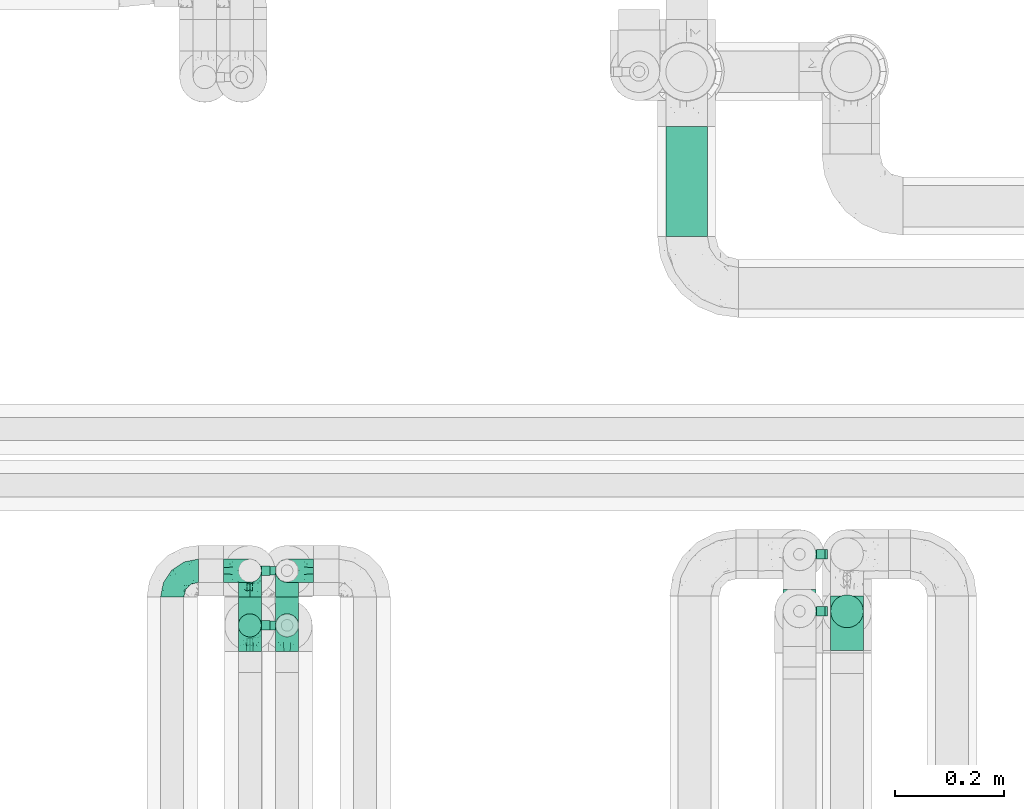
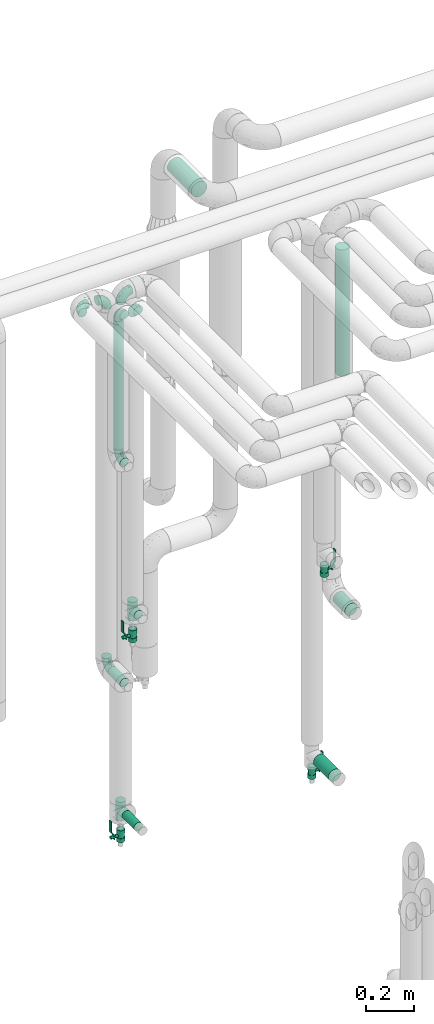
# One storey, part 637 of 824: 9 flow fittings, 7 flow segments, 4 flow controllers.
"""IFC2X3 building model written with IfcOpenShell, lengths in millimetres."""

from ifc_helpers import new_model, entity, si_unit, converted_unit, derived_unit, direction, frame, origin, origin_2d_with_axis, place, context, subcontext, project, spatial, polyline, circle, outline, extrude, faceted_brep, source, transform, mapped, material, material_list, type_object, type_shapes, element, save


model = new_model("IFC2X3")

# Units and contexts
model_context = context("Model", 3, precision=0.01, world=origin(), true_north=direction((6.12303176911189e-17, 1.0)))
body_context = subcontext(model_context, "Body", "Model", "MODEL_VIEW")
ifc_project = project(units=[si_unit("LENGTHUNIT", "METRE", prefix="MILLI"), si_unit("AREAUNIT", "SQUARE_METRE"), si_unit("VOLUMEUNIT", "CUBIC_METRE"), converted_unit("PLANEANGLEUNIT", "DEGREE", entity("IfcRatioMeasure", 0.0174532925199433), si_unit("PLANEANGLEUNIT", "RADIAN"), dimensions=[0, 0, 0, 0, 0, 0, 0]), si_unit("MASSUNIT", "GRAM", prefix="KILO"), derived_unit("MASSDENSITYUNIT", [(si_unit("MASSUNIT", "GRAM", prefix="KILO"), 1), (si_unit("LENGTHUNIT", "METRE"), -3)]), derived_unit("MOMENTOFINERTIAUNIT", [(si_unit("LENGTHUNIT", "METRE"), 4)]), si_unit("TIMEUNIT", "SECOND"), si_unit("FREQUENCYUNIT", "HERTZ"), si_unit("THERMODYNAMICTEMPERATUREUNIT", "DEGREE_CELSIUS"), derived_unit("THERMALTRANSMITTANCEUNIT", [(si_unit("MASSUNIT", "GRAM", prefix="KILO"), 1), (si_unit("THERMODYNAMICTEMPERATUREUNIT", "KELVIN"), -1), (si_unit("TIMEUNIT", "SECOND"), -3)]), derived_unit("VOLUMETRICFLOWRATEUNIT", [(si_unit("LENGTHUNIT", "METRE"), 3), (si_unit("TIMEUNIT", "SECOND"), -1)]), derived_unit("MASSFLOWRATEUNIT", [(si_unit("MASSUNIT", "GRAM", prefix="KILO"), 1), (si_unit("TIMEUNIT", "SECOND"), -1)]), derived_unit("ROTATIONALFREQUENCYUNIT", [(si_unit("TIMEUNIT", "SECOND"), -1)]), si_unit("ELECTRICCURRENTUNIT", "AMPERE"), si_unit("ELECTRICVOLTAGEUNIT", "VOLT"), si_unit("POWERUNIT", "WATT"), si_unit("FORCEUNIT", "NEWTON", prefix="KILO"), si_unit("ILLUMINANCEUNIT", "LUX"), si_unit("LUMINOUSFLUXUNIT", "LUMEN"), si_unit("LUMINOUSINTENSITYUNIT", "CANDELA"), derived_unit("USERDEFINED", [(si_unit("MASSUNIT", "GRAM", prefix="KILO"), -1), (si_unit("LENGTHUNIT", "METRE"), -2), (si_unit("TIMEUNIT", "SECOND"), 3), (si_unit("LUMINOUSFLUXUNIT", "LUMEN"), 1)]), derived_unit("LINEARVELOCITYUNIT", [(si_unit("LENGTHUNIT", "METRE"), 1), (si_unit("TIMEUNIT", "SECOND"), -1)]), si_unit("PRESSUREUNIT", "PASCAL"), derived_unit("USERDEFINED", [(si_unit("LENGTHUNIT", "METRE"), -2), (si_unit("MASSUNIT", "GRAM", prefix="KILO"), 1), (si_unit("TIMEUNIT", "SECOND"), -2)]), derived_unit("LINEARFORCEUNIT", [(si_unit("MASSUNIT", "GRAM", prefix="KILO"), 1), (si_unit("LENGTHUNIT", "METRE"), 1), (si_unit("TIMEUNIT", "SECOND"), -2), (si_unit("LENGTHUNIT", "METRE"), -1)]), derived_unit("PLANARFORCEUNIT", [(si_unit("MASSUNIT", "GRAM", prefix="KILO"), 1), (si_unit("LENGTHUNIT", "METRE"), 1), (si_unit("TIMEUNIT", "SECOND"), -2), (si_unit("LENGTHUNIT", "METRE"), -2)])], contexts=[model_context])

# Site, building, storey
site_placement = place(None, origin())
site = spatial("IfcSite", under=ifc_project, at=site_placement, CompositionType="ELEMENT")
building_placement = place(site_placement, origin())
building = spatial("IfcBuilding", under=site, at=building_placement, CompositionType="ELEMENT")
storey_placement = place(building_placement, frame((0.0, 0.0, 28200.0)))
storey = spatial("IfcBuildingStorey", under=building, at=storey_placement, CompositionType="ELEMENT", Elevation=28200.0)

# Flow segments
pipe_segment_type_1 = type_object("IfcPipeSegmentType", PredefinedType="NOTDEFINED")
flow_segment_1_placement = place(storey_placement, frame((31415.81, 19052.24, 2860.49)))
element("IfcFlowSegment", 1, at=flow_segment_1_placement, inside=storey, type_object=pipe_segment_type_1, context=body_context, shape_type="SweptSolid", body=[
    extrude(circle(Radius=38.0, at=origin_2d_with_axis()), frame((39.6, 0.0, 39.6), z_axis=(0.0, 1.0, 0.0), x_axis=(1.0, 0.0, 0.0)), (0.0, 0.0, 1.0), 201.196730959911),
])
pipe_segment_type_2 = type_object("IfcPipeSegmentType", PredefinedType="NOTDEFINED")
flow_segment_2_placement = place(storey_placement, frame((30634.3, 18293.2, 1107.7)))
element("IfcFlowSegment", 2, at=flow_segment_2_placement, inside=storey, type_object=pipe_segment_type_2, context=body_context, shape_type="SweptSolid", body=[
    extrude(circle(Radius=21.15, at=origin_2d_with_axis()), frame((22.75, 0.0, 22.75), z_axis=(0.0, 1.0, 0.0), x_axis=(-1.0, 0.0, 0.0)), (0.0, 0.0, 1.0), 99.999999953832),
])
flow_segment_3_placement = place(storey_placement, frame((30634.3, 18318.46, 2298.45)))
element("IfcFlowSegment", 3, at=flow_segment_3_placement, inside=storey, type_object=pipe_segment_type_2, context=body_context, shape_type="SweptSolid", body=[
    extrude(circle(Radius=21.15, at=origin_2d_with_axis()), frame((22.75, 22.75, 0.0)), (0.0, 0.0, 1.0), 653.551739999973),
])
flow_segment_4_placement = place(storey_placement, frame((30702.33, 18293.2, 352.25)))
element("IfcFlowSegment", 4, at=flow_segment_4_placement, inside=storey, type_object=pipe_segment_type_2, context=body_context, shape_type="SweptSolid", body=[
    extrude(circle(Radius=21.15, at=origin_2d_with_axis()), frame((22.75, 0.0, 22.75), z_axis=(0.0, 1.0, 0.0), x_axis=(-1.0, 0.0, 0.0)), (0.0, 0.0, 1.0), 99.9999999537973),
])
flow_segment_5_placement = place(storey_placement, frame((31717.07, 18295.2, 1088.53)))
element("IfcFlowSegment", 5, at=flow_segment_5_placement, inside=storey, type_object=pipe_segment_type_2, context=body_context, shape_type="SweptSolid", body=[
    extrude(circle(Radius=30.0, at=origin_2d_with_axis()), frame((31.6, 0.0, 31.6), z_axis=(0.0, 1.0, 0.0), x_axis=(-1.0, 0.0, 0.0)), (0.0, 0.0, 1.0), 99.9999999999989),
])
flow_segment_6_placement = place(storey_placement, frame((31717.07, 18335.35, 2281.01)))
element("IfcFlowSegment", 6, at=flow_segment_6_placement, inside=storey, type_object=pipe_segment_type_2, context=body_context, shape_type="SweptSolid", body=[
    extrude(circle(Radius=30.0, at=origin_2d_with_axis()), frame((31.6, 31.6, 0.0)), (0.0, 0.0, 1.0), 642.989986202028),
])
flow_segment_7_placement = place(storey_placement, frame((31630.07, 18281.2, 283.9)))
element("IfcFlowSegment", 7, at=flow_segment_7_placement, inside=storey, type_object=pipe_segment_type_2, context=body_context, shape_type="SweptSolid", body=[
    extrude(circle(Radius=30.0, at=origin_2d_with_axis()), frame((31.6, 0.0, 31.6), z_axis=(0.0, 1.0, 0.0), x_axis=(-1.0, 0.0, 0.0)), (0.0, 0.0, 1.0), 126.0),
])

# Flow controllers
ifc_material = material()
ifc_material_list = material_list([ifc_material, ifc_material, ifc_material, ifc_material, ifc_material])
valve_type = type_object("IfcValveType", PredefinedType="NOTDEFINED", material=ifc_material_list)
shared_shape_1 = source(origin(), body_context, "Body", "SweptSolid", [
    extrude(circle(Radius=17.5, at=origin_2d_with_axis()), frame((-30.5, 0.0, 0.0), z_axis=(1.0, 0.0, 0.0), x_axis=(0.0, 1.0, 0.0)), (0.0, 0.0, 1.0), 20.3333333333333),
    extrude(circle(Radius=16.0, at=origin_2d_with_axis()), frame((-10.17, 0.0, 0.0), z_axis=(1.0, 0.0, 0.0), x_axis=(0.0, 1.0, 0.0)), (0.0, 0.0, 1.0), 20.3333333333333),
    extrude(circle(Radius=17.5, at=origin_2d_with_axis()), frame((10.17, 0.0, 0.0), z_axis=(1.0, 0.0, 0.0), x_axis=(0.0, 1.0, 0.0)), (0.0, 0.0, 1.0), 20.3333333333333),
    extrude(outline(polyline([(-38.75, -5.0), (-38.75, -10.0), (-17.92, -10.0), (2.08, 5.0), (56.25, 5.0), (56.25, 10.0), (0.42, 10.0), (-19.58, -5.0), (-38.75, -5.0)])), frame((28.75, -8.75, 41.5), z_axis=(0.0, -1.0, 0.0), x_axis=(1.0, 0.0, 0.0)), (0.0, 0.0, -1.0), 17.5),
    extrude(circle(Radius=8.0, at=origin_2d_with_axis()), origin(), (0.0, 0.0, 1.0), 49.0),
])
type_shapes(valve_type, [shared_shape_1])
for number, where, z_axis, x_axis in (
    (8, (30725.07, 18441.2, 245.5), (-1.0, 0.0, 0.0), (0.0, 0.0, 1.0)),
    (9, (31661.66, 18471.2, 221.0), (1.0, 0.0, 0.0), (0.0, 0.0, 1.0)),
    (10, (31661.66, 18366.95, 1311.0), (1.0, 0.0, 0.0), (0.0, 0.0, 1.0)),
    (11, (30725.07, 18341.2, 1323.0), (-1.0, 0.0, 0.0), (0.0, 0.0, 1.0)),
):
    element("IfcFlowController", number, at=place(storey_placement, frame(where, z_axis=z_axis, x_axis=x_axis)), inside=storey, type_object=valve_type, material=ifc_material, context=body_context, shape_type="MappedRepresentation", body=[
        mapped(shared_shape_1, transform((0.0, 0.0, 0.0), scale=1.0)),
    ])

# Flow fittings
pipe_fitting_type_1 = type_object("IfcPipeFittingType", PredefinedType="NOTDEFINED", material=ifc_material)
shared_shape_2 = source(origin(), body_context, "Body", "Brep", [
    faceted_brep([(-48.0, 10.6, -18.36), (-48.0, 5.49, -20.48), (-48.0, 0.0, -21.2), (-48.0, -5.49, -20.48), (-48.0, -10.6, -18.36), (-48.0, -14.99, -14.99), (-48.0, -18.36, -10.6), (-48.0, -20.48, -5.49), (-48.0, -21.2, 0.0), (-48.0, -20.48, 5.49), (-48.0, -18.36, 10.6), (-48.0, -14.99, 14.99), (-48.0, -10.6, 18.36), (-48.0, -5.49, 20.48), (-48.0, 0.0, 21.2), (-48.0, 5.49, 20.48), (-48.0, 10.6, 18.36), (-48.0, 14.99, 14.99), (-48.0, 18.36, 10.6), (-48.0, 20.48, 5.49), (-48.0, 21.2, 0.0), (-48.0, 20.48, -5.49), (-48.0, 18.36, -10.6), (-48.0, 14.99, -14.99), (0.0, 48.0, -21.2), (-5.49, 48.0, -20.48), (-10.6, 48.0, -18.36), (-14.99, 48.0, -14.99), (-18.36, 48.0, -10.6), (-20.48, 48.0, -5.49), (-21.2, 48.0, 0.0), (-20.48, 48.0, 5.49), (-18.36, 48.0, 10.6), (-14.99, 48.0, 14.99), (-10.6, 48.0, 18.36), (-5.49, 48.0, 20.48), (0.0, 48.0, 21.2), (5.49, 48.0, 20.48), (10.6, 48.0, 18.36), (14.99, 48.0, 14.99), (18.36, 48.0, 10.6), (20.48, 48.0, 5.49), (21.2, 48.0, 0.0), (20.48, 48.0, -5.49), (18.36, 48.0, -10.6), (14.99, 48.0, -14.99), (10.6, 48.0, -18.36), (5.49, 48.0, -20.48), (-35.25, -16.22, 12.01), (-34.76, -18.57, 0.0), (-20.87, -12.37, 10.9), (-31.49, -11.78, 15.9), (-37.0, -2.58, 20.86), (-33.89, 3.62, 21.15), (-31.81, -18.14, 6.76), (-5.78, 5.78, 17.67), (-19.42, -4.1, 17.86), (-9.6, -3.39, 13.73), (-35.44, -7.73, 19.13), (11.78, 31.49, 15.9), (-5.93, -5.46, 6.95), (-18.45, -13.78, 5.46), (-10.29, -8.43, 0.0), (-24.6, 0.55, 20.62), (-37.28, 17.94, 13.81), (-33.38, 22.85, 9.59), (-41.46, 20.06, 8.75), (-29.51, 20.45, 15.16), (-15.04, 10.79, 21.13), (-7.08, 16.98, 20.93), (-8.39, 23.51, 21.15), (-40.86, 13.03, 17.26), (-8.05, 41.26, 19.83), (-3.21, 35.97, 21.14), (8.53, 19.66, 14.74), (4.1, 19.42, 17.86), (-37.72, 22.66, 4.78), (-37.07, 8.58, 19.98), (-13.0, 5.43, 19.97), (-3.78, 13.93, 19.7), (3.02, 8.69, 13.43), (-2.27, -0.05, 10.65), (6.22, 6.99, 7.09), (-22.25, 34.6, 9.45), (18.14, 31.81, 6.76), (16.22, 35.25, 12.01), (12.37, 20.87, 10.9), (7.73, 35.44, 19.13), (-21.52, -15.93, 0.0), (2.58, 37.0, 20.86), (18.57, 34.76, 0.0), (13.78, 18.45, 5.46), (15.93, 21.52, 0.0), (-20.03, -8.54, 14.9), (-28.6, 28.6, 5.16), (-24.79, 34.6, 0.0), (-34.6, 24.79, 0.0), (-22.81, 37.41, 4.68), (-23.36, 26.33, 14.79), (-13.68, 37.05, 17.49), (-17.72, 38.12, 13.73), (-26.25, 27.3, 11.24), (-9.71, 32.34, 20.14), (-17.26, 25.6, 18.71), (-26.33, 9.99, 20.77), (-24.06, 6.05, 21.2), (-25.02, 15.46, 19.56), (-24.3, 20.72, 17.57), (-31.95, 15.23, 17.8), (-13.53, 24.7, 20.21), (-17.6, 17.6, 20.6), (-0.55, 24.6, 20.62), (-11.41, -7.48, 10.43), (0.93, -0.93, 0.0), (8.43, 10.29, 0.0), (-11.41, -7.48, -10.43), (-20.1, -8.84, -14.66), (-9.6, -3.39, -13.73), (7.73, 35.44, -19.13), (4.1, 19.42, -17.86), (-0.55, 24.6, -20.62), (-38.12, 17.72, -13.73), (-37.05, 13.68, -17.49), (-32.34, 9.71, -20.14), (-41.26, 8.05, -19.83), (-37.41, 22.81, -4.68), (-23.51, 8.39, -21.15), (-35.97, 3.21, -21.14), (-28.6, 28.6, -5.16), (-31.81, -18.14, -6.76), (-18.45, -13.78, -5.46), (-25.6, 17.26, -18.71), (-19.42, -4.1, -17.86), (-17.94, 37.28, -13.81), (-22.85, 33.38, -9.59), (-20.06, 41.46, -8.75), (-31.49, -11.78, -15.9), (-35.25, -16.22, -12.01), (8.53, 19.66, -14.74), (11.78, 31.49, -15.9), (-9.99, 26.33, -20.77), (-6.05, 24.06, -21.2), (-10.79, 15.04, -21.13), (-37.0, -2.58, -20.86), (-16.98, 7.08, -20.93), (-5.43, 13.0, -19.97), (-13.93, 3.78, -19.7), (-20.87, -12.37, -10.9), (-26.33, 23.36, -14.79), (-22.66, 37.72, -4.78), (13.78, 18.45, -5.46), (18.14, 31.81, -6.76), (-15.46, 25.02, -19.56), (-20.72, 24.3, -17.57), (16.22, 35.25, -12.01), (-13.03, 40.86, -17.26), (-8.58, 37.07, -19.98), (2.58, 37.0, -20.86), (-3.62, 33.89, -21.15), (-34.6, 22.25, -9.45), (6.22, 6.99, -7.09), (-20.45, 29.51, -15.16), (-35.44, -7.73, -19.13), (12.37, 20.87, -10.9), (-27.3, 26.25, -11.24), (-15.23, 31.95, -17.8), (-24.7, 13.53, -20.21), (-24.6, 0.55, -20.62), (-5.78, 5.78, -17.67), (-17.6, 17.6, -20.6), (3.02, 8.69, -13.43), (-5.93, -5.46, -6.95), (-2.27, -0.05, -10.65)], [[[0, 1, 2, 3, 4, 5, 6, 7, 8, 9, 10, 11, 12, 13, 14, 15, 16, 17, 18, 19, 20, 21, 22, 23]], [[24, 25, 26, 27, 28, 29, 30, 31, 32, 33, 34, 35, 36, 37, 38, 39, 40, 41, 42, 43, 44, 45, 46, 47]], [[10, 48, 11]], [[9, 8, 49]], [[48, 50, 51]], [[14, 52, 53]], [[10, 54, 48]], [[9, 54, 10]], [[55, 56, 57]], [[51, 12, 11]], [[51, 58, 12]], [[59, 39, 38]], [[60, 61, 62]], [[58, 56, 63]], [[64, 65, 66]], [[67, 65, 64]], [[68, 69, 70]], [[16, 71, 17]], [[13, 52, 14]], [[35, 72, 73]], [[14, 53, 15]], [[17, 64, 18]], [[74, 59, 75]], [[20, 19, 76]], [[66, 19, 18]], [[77, 15, 53]], [[15, 77, 16]], [[69, 78, 79]], [[80, 81, 82]], [[32, 31, 83]], [[84, 85, 86]], [[59, 87, 75]], [[61, 54, 88]], [[36, 89, 37]], [[84, 41, 40]], [[36, 35, 73]], [[90, 41, 84]], [[40, 39, 85]], [[12, 58, 13]], [[85, 84, 40]], [[91, 84, 86]], [[84, 92, 90]], [[87, 38, 37]], [[93, 56, 51]], [[65, 94, 76]], [[94, 95, 96]], [[84, 91, 92]], [[95, 97, 30]], [[98, 99, 100]], [[76, 94, 96]], [[101, 98, 83]], [[100, 99, 33]], [[102, 70, 73]], [[103, 102, 99]], [[94, 97, 95]], [[72, 99, 102]], [[72, 35, 34]], [[34, 33, 99]], [[9, 49, 54]], [[87, 59, 38]], [[104, 105, 68]], [[106, 103, 107]], [[106, 77, 104]], [[71, 64, 17]], [[108, 107, 67]], [[33, 32, 100]], [[109, 103, 110]], [[102, 109, 70]], [[89, 73, 111]], [[50, 48, 54]], [[51, 11, 48]], [[56, 58, 51]], [[88, 54, 49]], [[52, 58, 63]], [[50, 112, 93]], [[56, 55, 78]], [[39, 59, 85]], [[86, 85, 59]], [[89, 87, 37]], [[42, 41, 90]], [[111, 79, 75]], [[111, 75, 87]], [[75, 55, 80]], [[104, 77, 53]], [[71, 77, 108]], [[32, 83, 100]], [[98, 100, 83]], [[99, 98, 103]], [[106, 107, 108]], [[68, 70, 110]], [[111, 73, 70]], [[68, 110, 104]], [[68, 63, 78]], [[57, 93, 112]], [[80, 55, 57]], [[61, 50, 54]], [[80, 82, 86]], [[81, 57, 112]], [[74, 86, 59]], [[60, 113, 82]], [[82, 114, 91]], [[101, 94, 65]], [[97, 94, 83]], [[73, 89, 36]], [[87, 89, 111]], [[58, 52, 13]], [[53, 52, 63]], [[104, 53, 105]], [[106, 104, 110]], [[20, 76, 96]], [[76, 19, 66]], [[103, 106, 110]], [[77, 106, 108]], [[103, 98, 107]], [[67, 107, 98]], [[67, 98, 101]], [[108, 67, 64]], [[53, 63, 105]], [[63, 68, 105]], [[83, 31, 97]], [[30, 97, 31]], [[62, 113, 60]], [[112, 61, 60]], [[61, 88, 62]], [[86, 82, 91]], [[56, 78, 63]], [[114, 82, 113]], [[114, 92, 91]], [[79, 78, 55]], [[75, 79, 55]], [[69, 79, 111]], [[70, 69, 111]], [[78, 69, 68]], [[77, 71, 16]], [[64, 71, 108]], [[64, 66, 18]], [[76, 66, 65]], [[99, 72, 34]], [[73, 72, 102]], [[94, 101, 83]], [[67, 101, 65]], [[75, 80, 74]], [[80, 86, 74]], [[70, 109, 110]], [[102, 103, 109]], [[50, 93, 51]], [[57, 56, 93]], [[61, 112, 50]], [[81, 112, 60]], [[82, 81, 60]], [[80, 57, 81]], [[115, 116, 117]], [[118, 119, 120]], [[121, 122, 23]], [[123, 124, 122]], [[96, 125, 20]], [[123, 126, 127]], [[128, 96, 95]], [[129, 130, 88]], [[123, 122, 131]], [[116, 132, 117]], [[133, 134, 135]], [[0, 124, 1]], [[5, 136, 137]], [[138, 119, 139]], [[129, 88, 49]], [[140, 141, 142]], [[6, 5, 137]], [[46, 118, 47]], [[143, 3, 2]], [[144, 145, 146]], [[6, 129, 7]], [[129, 137, 147]], [[127, 2, 1]], [[148, 122, 121]], [[128, 125, 96]], [[134, 128, 149]], [[95, 149, 128]], [[150, 151, 92]], [[30, 29, 149]], [[152, 131, 153]], [[27, 133, 28]], [[154, 45, 44]], [[136, 5, 4]], [[27, 26, 155]], [[156, 26, 25]], [[24, 157, 158]], [[24, 47, 157]], [[22, 21, 159]], [[160, 150, 114]], [[134, 133, 161]], [[142, 144, 126]], [[46, 139, 118]], [[162, 136, 4]], [[156, 25, 158]], [[1, 124, 127]], [[115, 147, 116]], [[45, 154, 139]], [[139, 46, 45]], [[154, 163, 139]], [[162, 4, 3]], [[42, 90, 43]], [[130, 129, 147]], [[49, 7, 129]], [[43, 151, 44]], [[0, 23, 122]], [[24, 158, 25]], [[136, 162, 132]], [[135, 29, 28]], [[43, 90, 151]], [[164, 148, 159]], [[152, 156, 140]], [[155, 133, 27]], [[165, 153, 161]], [[23, 22, 121]], [[123, 131, 166]], [[123, 166, 126]], [[143, 127, 167]], [[147, 137, 136]], [[8, 7, 49]], [[129, 6, 137]], [[143, 162, 3]], [[167, 146, 132]], [[167, 132, 162]], [[132, 168, 117]], [[44, 151, 154]], [[92, 151, 90]], [[163, 154, 151]], [[119, 118, 139]], [[157, 118, 120]], [[138, 139, 163]], [[119, 168, 145]], [[140, 156, 158]], [[155, 156, 165]], [[22, 159, 121]], [[148, 121, 159]], [[122, 148, 131]], [[152, 153, 165]], [[142, 126, 169]], [[167, 127, 126]], [[142, 169, 140]], [[142, 120, 145]], [[168, 170, 117]], [[160, 171, 172]], [[115, 172, 171]], [[171, 62, 130]], [[119, 170, 168]], [[170, 163, 160]], [[150, 163, 151]], [[113, 171, 160]], [[164, 128, 134]], [[125, 128, 159]], [[127, 143, 2]], [[162, 143, 167]], [[118, 157, 47]], [[158, 157, 120]], [[140, 158, 141]], [[152, 140, 169]], [[30, 149, 95]], [[149, 29, 135]], [[131, 152, 169]], [[156, 152, 165]], [[131, 148, 153]], [[161, 153, 148]], [[161, 148, 164]], [[165, 161, 133]], [[158, 120, 141]], [[120, 142, 141]], [[159, 21, 125]], [[20, 125, 21]], [[115, 130, 147]], [[114, 113, 160]], [[62, 171, 113]], [[62, 88, 130]], [[160, 163, 150]], [[150, 92, 114]], [[119, 145, 120]], [[146, 145, 168]], [[132, 146, 168]], [[144, 146, 167]], [[126, 144, 167]], [[145, 144, 142]], [[156, 155, 26]], [[133, 155, 165]], [[133, 135, 28]], [[149, 135, 134]], [[122, 124, 0]], [[127, 124, 123]], [[128, 164, 159]], [[161, 164, 134]], [[163, 170, 138]], [[170, 119, 138]], [[131, 169, 166]], [[126, 166, 169]], [[147, 136, 116]], [[132, 116, 136]], [[172, 115, 117]], [[130, 115, 171]], [[117, 170, 172]], [[160, 172, 170]]]),
])
type_shapes(pipe_fitting_type_1, [shared_shape_2])
for number, where, z_axis, x_axis in (
    (12, (30515.05, 18441.2, 3000.0), (0.0, 0.0, 1.0), (-1.0, 0.0, 0.0)),
    (13, (30657.05, 18441.2, 3000.0), (0.0, 1.0, 0.0), (1.0, 0.0, 0.0)),
    (14, (30725.07, 18441.2, 3000.0), (0.0, -1.0, 0.0), (-1.0, 0.0, 0.0)),
    (15, (30657.05, 18441.2, 1130.45), (-1.0, 0.0, 0.0), (0.0, 0.0, -1.0)),
    (16, (30657.05, 18341.2, 3000.0), (-1.0, 0.0, 0.0), (0.0, 1.0, 0.0)),
    (17, (30657.05, 18341.2, 2250.45), (-1.0, 0.0, 0.0), (0.0, 0.0, -1.0)),
    (18, (30725.07, 18341.2, 3000.0), (-1.0, 0.0, 0.0), (0.0, 1.0, 0.0)),
):
    element("IfcFlowFitting", number, at=place(storey_placement, frame(where, z_axis=z_axis, x_axis=x_axis)), inside=storey, type_object=pipe_fitting_type_1, material=ifc_material, context=body_context, shape_type="MappedRepresentation", body=[
        mapped(shared_shape_2, transform((0.0, 0.0, 0.0), scale=1.0)),
    ])
pipe_fitting_type_2 = type_object("IfcPipeFittingType", PredefinedType="NOTDEFINED", material=ifc_material)
shared_shape_3 = source(origin(), body_context, "Body", "Brep", [
    faceted_brep([(-48.0, 10.6, -18.36), (-48.0, 5.49, -20.48), (-48.0, 0.0, -21.2), (-48.0, -5.49, -20.48), (-48.0, -10.6, -18.36), (-48.0, -14.99, -14.99), (-48.0, -18.36, -10.6), (-48.0, -20.48, -5.49), (-48.0, -21.2, 0.0), (-48.0, -20.48, 5.49), (-48.0, -18.36, 10.6), (-48.0, -14.99, 14.99), (-48.0, -10.6, 18.36), (-48.0, -5.49, 20.48), (-48.0, 0.0, 21.2), (-48.0, 5.49, 20.48), (-48.0, 10.6, 18.36), (-48.0, 14.99, 14.99), (-48.0, 18.36, 10.6), (-48.0, 20.48, 5.49), (-48.0, 21.2, 0.0), (-48.0, 20.48, -5.49), (-48.0, 18.36, -10.6), (-48.0, 14.99, -14.99), (48.0, 0.0, -21.2), (48.0, 5.49, -20.48), (48.0, 10.6, -18.36), (48.0, 14.99, -14.99), (48.0, 18.36, -10.6), (48.0, 20.48, -5.49), (48.0, 21.2, 0.0), (48.0, 20.48, 5.49), (48.0, 18.36, 10.6), (48.0, 14.99, 14.99), (48.0, 10.6, 18.36), (48.0, 5.49, 20.48), (48.0, 0.0, 21.2), (48.0, -5.49, 20.48), (48.0, -10.6, 18.36), (48.0, -14.99, 14.99), (48.0, -18.36, 10.6), (48.0, -20.48, 5.49), (48.0, -21.2, 0.0), (48.0, -20.48, -5.49), (48.0, -18.36, -10.6), (48.0, -14.99, -14.99), (48.0, -10.6, -18.36), (48.0, -5.49, -20.48), (20.43, -20.43, 5.66), (21.2, -21.2, 0.0), (-21.2, -21.2, 0.0), (18.35, -18.35, 10.62), (11.88, -11.88, 17.56), (15.38, -15.38, 14.59), (-20.43, -20.43, 5.66), (-18.35, -18.35, 10.62), (-15.38, -15.38, 14.59), (-11.88, -11.88, 17.56), (-8.06, -8.06, 19.61), (8.06, -8.06, 19.61), (4.07, -4.07, 20.81), (0.0, 0.0, 21.2), (-4.07, -4.07, 20.81), (4.07, -4.07, -20.81), (0.0, 0.0, -21.2), (-4.07, -4.07, -20.81), (-8.06, -8.06, -19.61), (8.06, -8.06, -19.61), (11.88, -11.88, -17.56), (15.38, -15.38, -14.59), (18.35, -18.35, -10.62), (20.43, -20.43, -5.66), (-11.88, -11.88, -17.56), (-15.38, -15.38, -14.59), (-20.43, -20.43, -5.66), (-18.35, -18.35, -10.62), (0.0, -48.0, -21.2), (5.49, -48.0, -20.48), (10.6, -48.0, -18.36), (14.99, -48.0, -14.99), (18.36, -48.0, -10.6), (20.48, -48.0, -5.49), (21.2, -48.0, 0.0), (20.48, -48.0, 5.49), (18.36, -48.0, 10.6), (14.99, -48.0, 14.99), (10.6, -48.0, 18.36), (5.49, -48.0, 20.48), (0.0, -48.0, 21.2), (-5.49, -48.0, 20.48), (-10.6, -48.0, 18.36), (-14.99, -48.0, 14.99), (-18.36, -48.0, 10.6), (-20.48, -48.0, 5.49), (-21.2, -48.0, 0.0), (-20.48, -48.0, -5.49), (-18.36, -48.0, -10.6), (-14.99, -48.0, -14.99), (-10.6, -48.0, -18.36), (-5.49, -48.0, -20.48)], [[[0, 1, 2, 3, 4, 5, 6, 7, 8, 9, 10, 11, 12, 13, 14, 15, 16, 17, 18, 19, 20, 21, 22, 23]], [[24, 25, 26, 27, 28, 29, 30, 31, 32, 33, 34, 35, 36, 37, 38, 39, 40, 41, 42, 43, 44, 45, 46, 47]], [[41, 40, 48]], [[42, 41, 49]], [[50, 9, 8]], [[49, 41, 48]], [[40, 51, 48]], [[39, 38, 52]], [[51, 40, 53]], [[52, 53, 39]], [[53, 40, 39]], [[50, 54, 9]], [[9, 54, 10]], [[54, 55, 10]], [[56, 57, 11]], [[11, 10, 56]], [[11, 57, 12]], [[56, 10, 55]], [[12, 57, 58]], [[52, 38, 59]], [[60, 36, 61]], [[62, 61, 14]], [[59, 37, 60]], [[37, 59, 38]], [[60, 37, 36]], [[61, 36, 35, 15, 14]], [[32, 31, 19, 18]], [[17, 16, 34, 33]], [[18, 17, 33, 32]], [[35, 34, 16, 15]], [[20, 19, 31, 30]], [[62, 13, 58]], [[13, 62, 14]], [[58, 13, 12]], [[27, 23, 22, 28]], [[22, 21, 29, 28]], [[0, 23, 27, 26]], [[20, 30, 29, 21]], [[24, 47, 63]], [[24, 64, 2, 1, 25]], [[64, 24, 63]], [[2, 64, 65]], [[26, 25, 1, 0]], [[65, 66, 3]], [[2, 65, 3]], [[66, 4, 3]], [[63, 47, 67]], [[46, 45, 68]], [[69, 68, 45]], [[44, 70, 69]], [[69, 45, 44]], [[46, 68, 67]], [[43, 42, 49]], [[7, 50, 8]], [[43, 71, 44]], [[71, 43, 49]], [[44, 71, 70]], [[72, 4, 66]], [[72, 5, 4]], [[5, 72, 73]], [[5, 73, 6]], [[74, 50, 7]], [[75, 74, 6]], [[74, 7, 6]], [[75, 6, 73]], [[46, 67, 47]], [[76, 77, 78, 79, 80, 81, 82, 83, 84, 85, 86, 87, 88, 89, 90, 91, 92, 93, 94, 95, 96, 97, 98, 99]], [[50, 94, 93]], [[54, 50, 93]], [[91, 90, 57]], [[56, 92, 91]], [[54, 93, 92]], [[58, 90, 89]], [[55, 54, 92]], [[56, 55, 92]], [[58, 57, 90]], [[88, 61, 62]], [[58, 89, 62]], [[56, 91, 57]], [[62, 89, 88]], [[60, 88, 87]], [[86, 59, 87]], [[84, 83, 48]], [[53, 85, 84]], [[52, 86, 85]], [[49, 83, 82]], [[59, 60, 87]], [[52, 59, 86]], [[49, 48, 83]], [[51, 53, 84]], [[48, 51, 84]], [[52, 85, 53]], [[88, 60, 61]], [[82, 81, 49]], [[71, 49, 81]], [[69, 80, 79]], [[79, 78, 68]], [[71, 81, 80]], [[67, 78, 77]], [[70, 71, 80]], [[69, 70, 80]], [[67, 68, 78]], [[76, 64, 63]], [[67, 77, 63]], [[69, 79, 68]], [[63, 77, 76]], [[65, 76, 99]], [[98, 66, 99]], [[96, 95, 74]], [[73, 97, 96]], [[72, 98, 97]], [[50, 95, 94]], [[66, 65, 99]], [[72, 66, 98]], [[50, 74, 95]], [[75, 73, 96]], [[74, 75, 96]], [[72, 97, 73]], [[76, 65, 64]]]),
])
type_shapes(pipe_fitting_type_2, [shared_shape_3])
for number, where, z_axis, x_axis in (
    (19, (30725.07, 18341.2, 1452.5), (-1.0, 0.0, 0.0), (0.0, 0.0, 1.0)),
    (20, (30725.07, 18441.2, 375.0), (-1.0, 0.0, 0.0), (0.0, 0.0, 1.0)),
):
    element("IfcFlowFitting", number, at=place(storey_placement, frame(where, z_axis=z_axis, x_axis=x_axis)), inside=storey, type_object=pipe_fitting_type_2, material=ifc_material, context=body_context, shape_type="MappedRepresentation", body=[
        mapped(shared_shape_3, transform((0.0, 0.0, 0.0), scale=1.0)),
    ])

save(model, "model.ifc")
